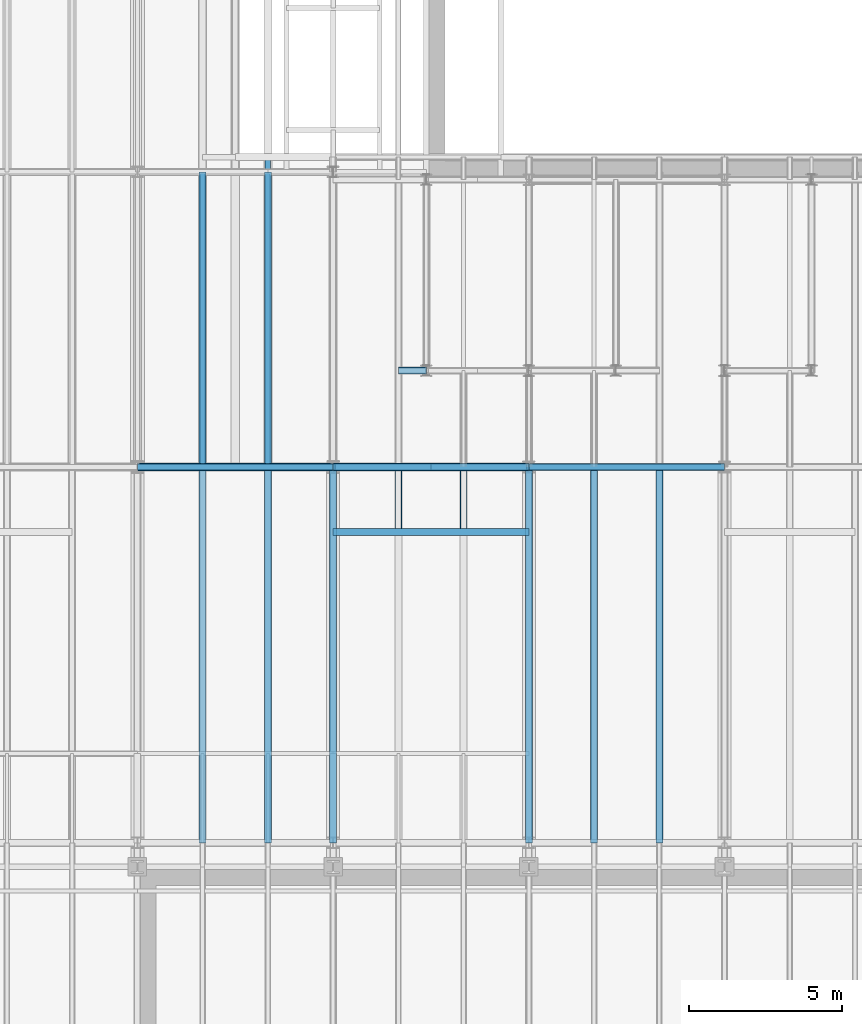
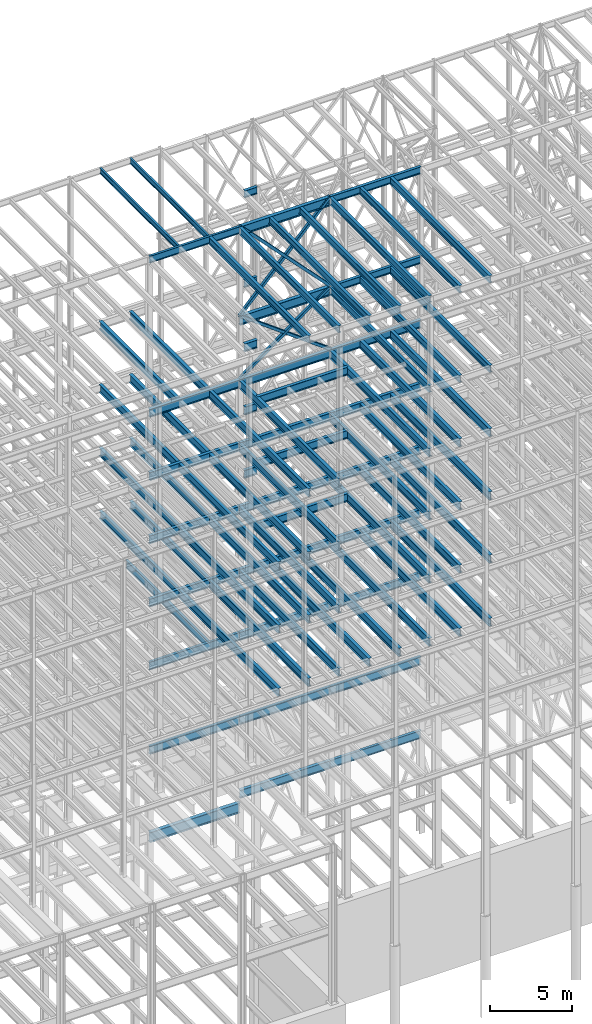
# One storey, part 132 of 150: 84 beams.
"""IFC2X3 building model written with IfcOpenShell, lengths in millimetres."""

from ifc_helpers import new_model, si_unit, frame, origin_with_axes, origin_2d_with_axis, place, context, subcontext, project, spatial, hollow_rectangle, i_section, extrude, material, type_object, element, save


model = new_model("IFC2X3")

# Units and contexts
model_context = context("Model", 3, precision=1e-05, world=origin_with_axes())
body_context = subcontext(model_context, "Body", "Model", "MODEL_VIEW")
ifc_project = project(units=[si_unit("LENGTHUNIT", "METRE", prefix="MILLI"), si_unit("AREAUNIT", "SQUARE_METRE"), si_unit("VOLUMEUNIT", "CUBIC_METRE"), si_unit("MASSUNIT", "GRAM", prefix="KILO"), si_unit("TIMEUNIT", "SECOND"), si_unit("PLANEANGLEUNIT", "RADIAN"), si_unit("SOLIDANGLEUNIT", "STERADIAN"), si_unit("THERMODYNAMICTEMPERATUREUNIT", "DEGREE_CELSIUS"), si_unit("LUMINOUSINTENSITYUNIT", "LUMEN")], contexts=[model_context])

# Site, building, storey
site_placement = place(None, origin_with_axes())
site = spatial("IfcSite", under=ifc_project, at=site_placement, CompositionType="ELEMENT")
building_placement = place(site_placement, origin_with_axes())
building = spatial("IfcBuilding", under=site, at=building_placement, Name="Undefined", CompositionType="ELEMENT")
storey_placement = place(building_placement, origin_with_axes())
storey = spatial("IfcBuildingStorey", under=building, at=storey_placement, Name="Undefined", CompositionType="ELEMENT", Elevation=0.0)

# Beams
ifc_material_1 = material()
beam_type_1 = type_object("IfcBeamType", Name="HSS8X8X3/8", PredefinedType="NOTDEFINED")
for number, where, z_axis, x_axis, name in (
    (1, (56591.2, 22479.0, 54483.0), (0.593852272176561, 0.0, 0.804574097787603), (-0.804574097787604, 0.0, 0.59385227217656), "BEAM"),
    (2, (50190.4, 22479.0, 54483.0), (-0.593852272176556, 0.0, 0.804574097787607), (0.804574097787604, 0.0, 0.59385227217656), "BEAM"),
):
    element("IfcBeam", number, at=place(storey_placement, frame(where, z_axis=z_axis, x_axis=x_axis)), inside=storey, type_object=beam_type_1, material=ifc_material_1, Name=name, ObjectType="HSS8X8X3/8", context=body_context, shape_type="SweptSolid", body=[
        extrude(hollow_rectangle(XDim=203.2, YDim=203.2, WallThickness=9.525, InnerFilletRadius=9.5249, OuterFilletRadius=19.0499, at=origin_2d_with_axis()), frame((7955.51355978985, 0.0, -1.81898940354586e-12), z_axis=(-1.0, 0.0, 0.0), x_axis=(0.0, -1.0, 0.0)), (0.0, 0.0, 1.0), 7955.51355978984),
    ])
beam_type_2 = type_object("IfcBeamType", Name="HSS8X8X1/4", PredefinedType="NOTDEFINED")
beam_1_placement = place(storey_placement, frame((56591.2, 22479.0, 59207.4), z_axis=(0.723355546413844, 0.0, 0.690475744304121), x_axis=(-0.690475744304122, 0.0, 0.723355546413843)))
element("IfcBeam", 3, at=beam_1_placement, inside=storey, type_object=beam_type_2, material=ifc_material_1, Name="BEAM", ObjectType="HSS8X8X1/4", context=body_context, shape_type="SweptSolid", body=[
    extrude(hollow_rectangle(XDim=203.2, YDim=203.2, WallThickness=6.35, InnerFilletRadius=6.3499, OuterFilletRadius=12.6999, at=origin_2d_with_axis()), frame((9270.13009617449, 3.63797880709171e-12, 0.0), z_axis=(-1.0, 0.0, 0.0), x_axis=(0.0, -1.0, 0.0)), (0.0, 0.0, 1.0), 9270.13009617449),
])
beam_2_placement = place(storey_placement, frame((50190.4, 22479.0, 59207.4), z_axis=(-0.723355546413844, 0.0, 0.690475744304121), x_axis=(0.690475744304122, 0.0, 0.723355546413843)))
element("IfcBeam", 4, at=beam_2_placement, inside=storey, type_object=beam_type_2, material=ifc_material_1, Name="BEAM", ObjectType="HSS8X8X1/4", context=body_context, shape_type="SweptSolid", body=[
    extrude(hollow_rectangle(XDim=203.2, YDim=203.2, WallThickness=6.35, InnerFilletRadius=6.3499, OuterFilletRadius=12.6999, at=origin_2d_with_axis()), frame((9270.13009617449, 3.63797880709171e-12, 0.0), z_axis=(-1.0, 0.0, 0.0), x_axis=(0.0, -1.0, 0.0)), (0.0, 0.0, 1.0), 9270.1300961745),
])
ifc_material_2 = material(Name="STEEL/A992")
beam_type_3 = type_object("IfcBeamType", Name="W16X31", PredefinedType="NOTDEFINED")
for number, where, z_axis, x_axis, name in (
    (5, (48056.8, 22479.0, 65711.3875), (0.0, 0.0, 1.0), (0.0, 1.0, 0.0), "BEAM"),
    (6, (45923.2, 22479.0, 65711.3875), (0.0, 0.0, 1.0), (0.0, 1.0, 0.0), "BEAM"),
):
    element("IfcBeam", number, at=place(storey_placement, frame(where, z_axis=z_axis, x_axis=x_axis)), inside=storey, type_object=beam_type_3, material=ifc_material_2, Name=name, ObjectType="W16X31", context=body_context, shape_type="SweptSolid", body=[
        extrude(i_section(OverallWidth=140.462, OverallDepth=403.225, WebThickness=6.3499, FlangeThickness=11.176, FilletRadius=17.399, at=origin_2d_with_axis()), frame((9652.0, 0.0, 0.0), z_axis=(-1.0, 0.0, 0.0), x_axis=(0.0, -1.0, 0.0)), (0.0, 0.0, 1.0), 9652.0),
    ])
beam_type_4 = type_object("IfcBeamType", Name="W21X50", PredefinedType="NOTDEFINED")
beam_3_placement = place(storey_placement, frame((43789.6, 22479.0, 65647.8875), z_axis=(0.0, 0.0, 1.0), x_axis=(1.0, 0.0, 0.0)))
element("IfcBeam", 7, at=beam_3_placement, inside=storey, type_object=beam_type_4, material=ifc_material_2, Name="BEAM", ObjectType="W21X50", context=body_context, shape_type="SweptSolid", body=[
    extrude(i_section(OverallWidth=165.862, OverallDepth=530.225, WebThickness=9.5249, FlangeThickness=13.589, FilletRadius=18.1609, at=origin_2d_with_axis()), frame((6400.80000000001, 0.0, 0.0), z_axis=(-1.0, 0.0, 0.0), x_axis=(0.0, -1.0, 0.0)), (0.0, 0.0, 1.0), 6400.80000000001),
])
beam_type_5 = type_object("IfcBeamType", Name="W24X68", PredefinedType="NOTDEFINED")
beam_4_placement = place(storey_placement, frame((50190.4, 20345.4, 54181.375), z_axis=(0.0, 0.0, 1.0), x_axis=(1.0, 0.0, 0.0)))
element("IfcBeam", 8, at=beam_4_placement, inside=storey, type_object=beam_type_5, material=ifc_material_2, Name="BEAM", ObjectType="W24X68", context=body_context, shape_type="SweptSolid", body=[
    extrude(i_section(OverallWidth=227.838, OverallDepth=603.25, WebThickness=11.1125, FlangeThickness=14.859, FilletRadius=23.2409, at=origin_2d_with_axis()), frame((6400.79935992001, 0.0, 0.0), z_axis=(-1.0, 0.0, 0.0), x_axis=(0.0, -1.0, 0.0)), (0.0, 0.0, 1.0), 6400.79935992),
])
beam_5_placement = place(storey_placement, frame((52324.0, 25628.6, 54181.375), z_axis=(0.0, 0.0, 1.0), x_axis=(1.0, 0.0, 0.0)))
element("IfcBeam", 9, at=beam_5_placement, inside=storey, type_object=beam_type_5, material=ifc_material_2, Name="BEAM", ObjectType="W24X68", context=body_context, shape_type="SweptSolid", body=[
    extrude(i_section(OverallWidth=227.838, OverallDepth=603.25, WebThickness=11.1125, FlangeThickness=14.859, FilletRadius=23.2409, at=origin_2d_with_axis()), frame((914.400000000009, 0.0, 0.0), z_axis=(-1.0, 0.0, 0.0), x_axis=(0.0, -1.0, 0.0)), (0.0, 0.0, 1.0), 914.400000000001),
])
for number, where, z_axis, x_axis, name in (
    (10, (48056.8, 22479.0, 54181.375), (0.0, 0.0, 1.0), (0.0, 1.0, 0.0), "BEAM"),
    (11, (45923.2, 22479.0, 54181.375), (0.0, 0.0, 1.0), (0.0, 1.0, 0.0), "BEAM"),
):
    element("IfcBeam", number, at=place(storey_placement, frame(where, z_axis=z_axis, x_axis=x_axis)), inside=storey, type_object=beam_type_5, material=ifc_material_2, Name=name, ObjectType="W24X68", context=body_context, shape_type="SweptSolid", body=[
        extrude(i_section(OverallWidth=227.838, OverallDepth=603.25, WebThickness=11.1125, FlangeThickness=14.859, FilletRadius=23.2409, at=origin_2d_with_axis()), frame((9652.0, 0.0, 0.0), z_axis=(-1.0, 0.0, 0.0), x_axis=(0.0, -1.0, 0.0)), (0.0, 0.0, 1.0), 9652.0),
    ])
beam_6_placement = place(storey_placement, frame((56591.2, 22479.0, 54181.375), z_axis=(0.0, 0.0, 1.0), x_axis=(1.0, 0.0, 0.0)))
element("IfcBeam", 12, at=beam_6_placement, inside=storey, type_object=beam_type_5, material=ifc_material_2, Name="BEAM", ObjectType="W24X68", context=body_context, shape_type="SweptSolid", body=[
    extrude(i_section(OverallWidth=227.838, OverallDepth=603.25, WebThickness=11.1125, FlangeThickness=14.859, FilletRadius=23.2409, at=origin_2d_with_axis()), frame((6400.79935992001, 0.0, 0.0), z_axis=(-1.0, 0.0, 0.0), x_axis=(0.0, -1.0, 0.0)), (0.0, 0.0, 1.0), 6400.79935992001),
])
beam_7_placement = place(storey_placement, frame((50190.4, 22479.0, 54181.375), z_axis=(0.0, 0.0, 1.0), x_axis=(1.0, 0.0, 0.0)))
element("IfcBeam", 13, at=beam_7_placement, inside=storey, type_object=beam_type_5, material=ifc_material_2, Name="BEAM", ObjectType="W24X68", context=body_context, shape_type="SweptSolid", body=[
    extrude(i_section(OverallWidth=227.838, OverallDepth=603.25, WebThickness=11.1125, FlangeThickness=14.859, FilletRadius=23.2409, at=origin_2d_with_axis()), frame((6400.80000000001, 0.0, 0.0), z_axis=(-1.0, 0.0, 0.0), x_axis=(0.0, -1.0, 0.0)), (0.0, 0.0, 1.0), 6400.8),
])
beam_8_placement = place(storey_placement, frame((43789.6, 22479.0, 54181.375), z_axis=(0.0, 0.0, 1.0), x_axis=(1.0, 0.0, 0.0)))
element("IfcBeam", 14, at=beam_8_placement, inside=storey, type_object=beam_type_5, material=ifc_material_2, Name="BEAM", ObjectType="W24X68", context=body_context, shape_type="SweptSolid", body=[
    extrude(i_section(OverallWidth=227.838, OverallDepth=603.25, WebThickness=11.1125, FlangeThickness=14.859, FilletRadius=23.2409, at=origin_2d_with_axis()), frame((6400.79935992001, 0.0, 0.0), z_axis=(-1.0, 0.0, 0.0), x_axis=(0.0, -1.0, 0.0)), (0.0, 0.0, 1.0), 6400.79935992001),
])
for number, where, z_axis, x_axis, name in (
    (15, (60858.4, 10185.4, 54181.375), (0.0, 0.0, 1.0), (0.0, 1.0, 0.0), "BEAM"),
    (16, (58724.8, 10185.4, 54181.375), (0.0, 0.0, 1.0), (0.0, 1.0, 0.0), "BEAM"),
    (17, (56591.2, 10185.4, 54181.375), (0.0, 0.0, 1.0), (0.0, 1.0, 0.0), "BEAM"),
    (18, (50190.4, 10185.4, 54181.375), (0.0, 0.0, 1.0), (0.0, 1.0, 0.0), "BEAM"),
    (19, (48056.8, 10185.4, 54181.375), (0.0, 0.0, 1.0), (0.0, 1.0, 0.0), "BEAM"),
):
    element("IfcBeam", number, at=place(storey_placement, frame(where, z_axis=z_axis, x_axis=x_axis)), inside=storey, type_object=beam_type_5, material=ifc_material_2, Name=name, ObjectType="W24X68", context=body_context, shape_type="SweptSolid", body=[
        extrude(i_section(OverallWidth=227.838, OverallDepth=603.25, WebThickness=11.1125, FlangeThickness=14.859, FilletRadius=23.2409, at=origin_2d_with_axis()), frame((12293.6, 0.0, 0.0), z_axis=(-1.0, 0.0, 0.0), x_axis=(0.0, -1.0, 0.0)), (0.0, 0.0, 1.0), 12293.6),
    ])
beam_9_placement = place(storey_placement, frame((50190.4, 20345.4, 49456.975), z_axis=(0.0, 0.0, 1.0), x_axis=(1.0, 0.0, 0.0)))
element("IfcBeam", 20, at=beam_9_placement, inside=storey, type_object=beam_type_5, material=ifc_material_2, Name="BEAM", ObjectType="W24X68", context=body_context, shape_type="SweptSolid", body=[
    extrude(i_section(OverallWidth=227.838, OverallDepth=603.25, WebThickness=11.1125, FlangeThickness=14.859, FilletRadius=23.2409, at=origin_2d_with_axis()), frame((6400.79935992001, 0.0, 0.0), z_axis=(-1.0, 0.0, 0.0), x_axis=(0.0, -1.0, 0.0)), (0.0, 0.0, 1.0), 6400.79935992),
])
beam_10_placement = place(storey_placement, frame((52324.0, 25628.6, 49456.975), z_axis=(0.0, 0.0, 1.0), x_axis=(1.0, 0.0, 0.0)))
element("IfcBeam", 21, at=beam_10_placement, inside=storey, type_object=beam_type_5, material=ifc_material_2, Name="BEAM", ObjectType="W24X68", context=body_context, shape_type="SweptSolid", body=[
    extrude(i_section(OverallWidth=227.838, OverallDepth=603.25, WebThickness=11.1125, FlangeThickness=14.859, FilletRadius=23.2409, at=origin_2d_with_axis()), frame((914.400000000009, 0.0, 0.0), z_axis=(-1.0, 0.0, 0.0), x_axis=(0.0, -1.0, 0.0)), (0.0, 0.0, 1.0), 914.400000000001),
])
for number, where, z_axis, x_axis, name in (
    (22, (48056.8, 22479.0, 49456.975), (0.0, 0.0, 1.0), (0.0, 1.0, 0.0), "BEAM"),
    (23, (45923.2, 22479.0, 49456.975), (0.0, 0.0, 1.0), (0.0, 1.0, 0.0), "BEAM"),
):
    element("IfcBeam", number, at=place(storey_placement, frame(where, z_axis=z_axis, x_axis=x_axis)), inside=storey, type_object=beam_type_5, material=ifc_material_2, Name=name, ObjectType="W24X68", context=body_context, shape_type="SweptSolid", body=[
        extrude(i_section(OverallWidth=227.838, OverallDepth=603.25, WebThickness=11.1125, FlangeThickness=14.859, FilletRadius=23.2409, at=origin_2d_with_axis()), frame((9652.0, 0.0, 0.0), z_axis=(-1.0, 0.0, 0.0), x_axis=(0.0, -1.0, 0.0)), (0.0, 0.0, 1.0), 9652.0),
    ])
beam_11_placement = place(storey_placement, frame((56591.2, 22479.0, 49456.975), z_axis=(0.0, 0.0, 1.0), x_axis=(1.0, 0.0, 0.0)))
element("IfcBeam", 24, at=beam_11_placement, inside=storey, type_object=beam_type_5, material=ifc_material_2, Name="BEAM", ObjectType="W24X68", context=body_context, shape_type="SweptSolid", body=[
    extrude(i_section(OverallWidth=227.838, OverallDepth=603.25, WebThickness=11.1125, FlangeThickness=14.859, FilletRadius=23.2409, at=origin_2d_with_axis()), frame((6400.79935992001, 0.0, 0.0), z_axis=(-1.0, 0.0, 0.0), x_axis=(0.0, -1.0, 0.0)), (0.0, 0.0, 1.0), 6400.79935992001),
])
beam_12_placement = place(storey_placement, frame((50190.4, 22479.0, 49456.975), z_axis=(0.0, 0.0, 1.0), x_axis=(1.0, 0.0, 0.0)))
element("IfcBeam", 25, at=beam_12_placement, inside=storey, type_object=beam_type_5, material=ifc_material_2, Name="BEAM", ObjectType="W24X68", context=body_context, shape_type="SweptSolid", body=[
    extrude(i_section(OverallWidth=227.838, OverallDepth=603.25, WebThickness=11.1125, FlangeThickness=14.859, FilletRadius=23.2409, at=origin_2d_with_axis()), frame((6400.79935992001, 0.0, 0.0), z_axis=(-1.0, 0.0, 0.0), x_axis=(0.0, -1.0, 0.0)), (0.0, 0.0, 1.0), 6400.79935992),
])
beam_13_placement = place(storey_placement, frame((43789.6, 22479.0, 49456.975), z_axis=(0.0, 0.0, 1.0), x_axis=(1.0, 0.0, 0.0)))
element("IfcBeam", 26, at=beam_13_placement, inside=storey, type_object=beam_type_5, material=ifc_material_2, Name="BEAM", ObjectType="W24X68", context=body_context, shape_type="SweptSolid", body=[
    extrude(i_section(OverallWidth=227.838, OverallDepth=603.25, WebThickness=11.1125, FlangeThickness=14.859, FilletRadius=23.2409, at=origin_2d_with_axis()), frame((6400.79935992001, 0.0, 0.0), z_axis=(-1.0, 0.0, 0.0), x_axis=(0.0, -1.0, 0.0)), (0.0, 0.0, 1.0), 6400.79935992001),
])
for number, where, z_axis, x_axis, name in (
    (27, (60858.4, 10185.4, 49456.975), (0.0, 0.0, 1.0), (0.0, 1.0, 0.0), "BEAM"),
    (28, (58724.8, 10185.4, 49456.975), (0.0, 0.0, 1.0), (0.0, 1.0, 0.0), "BEAM"),
    (29, (56591.2, 10185.4, 49456.975), (0.0, 0.0, 1.0), (0.0, 1.0, 0.0), "BEAM"),
    (30, (50190.4, 10185.4, 49456.975), (0.0, 0.0, 1.0), (0.0, 1.0, 0.0), "BEAM"),
    (31, (48056.8, 10185.4, 49456.975), (0.0, 0.0, 1.0), (0.0, 1.0, 0.0), "BEAM"),
    (32, (45923.2, 10185.4, 49456.975), (0.0, 0.0, 1.0), (0.0, 1.0, 0.0), "BEAM"),
):
    element("IfcBeam", number, at=place(storey_placement, frame(where, z_axis=z_axis, x_axis=x_axis)), inside=storey, type_object=beam_type_5, material=ifc_material_2, Name=name, ObjectType="W24X68", context=body_context, shape_type="SweptSolid", body=[
        extrude(i_section(OverallWidth=227.838, OverallDepth=603.25, WebThickness=11.1125, FlangeThickness=14.859, FilletRadius=23.2409, at=origin_2d_with_axis()), frame((12293.6, 0.0, 0.0), z_axis=(-1.0, 0.0, 0.0), x_axis=(0.0, -1.0, 0.0)), (0.0, 0.0, 1.0), 12293.6),
    ])
beam_14_placement = place(storey_placement, frame((50190.4, 20345.4, 44732.575), z_axis=(0.0, 0.0, 1.0), x_axis=(1.0, 0.0, 0.0)))
element("IfcBeam", 33, at=beam_14_placement, inside=storey, type_object=beam_type_5, material=ifc_material_2, Name="BEAM", ObjectType="W24X68", context=body_context, shape_type="SweptSolid", body=[
    extrude(i_section(OverallWidth=227.838, OverallDepth=603.25, WebThickness=11.1125, FlangeThickness=14.859, FilletRadius=23.2409, at=origin_2d_with_axis()), frame((6400.79935992001, 0.0, 0.0), z_axis=(-1.0, 0.0, 0.0), x_axis=(0.0, -1.0, 0.0)), (0.0, 0.0, 1.0), 6400.79935992),
])
beam_15_placement = place(storey_placement, frame((52324.0, 25628.6, 44732.575), z_axis=(0.0, 0.0, 1.0), x_axis=(1.0, 0.0, 0.0)))
element("IfcBeam", 34, at=beam_15_placement, inside=storey, type_object=beam_type_5, material=ifc_material_2, Name="BEAM", ObjectType="W24X68", context=body_context, shape_type="SweptSolid", body=[
    extrude(i_section(OverallWidth=227.838, OverallDepth=603.25, WebThickness=11.1125, FlangeThickness=14.859, FilletRadius=23.2409, at=origin_2d_with_axis()), frame((914.400000000009, 0.0, 0.0), z_axis=(-1.0, 0.0, 0.0), x_axis=(0.0, -1.0, 0.0)), (0.0, 0.0, 1.0), 914.400000000001),
])
for number, where, z_axis, x_axis, name in (
    (35, (48056.8, 22479.0, 44732.575), (0.0, 0.0, 1.0), (0.0, 1.0, 0.0), "BEAM"),
    (36, (45923.2, 22479.0, 44732.575), (0.0, 0.0, 1.0), (0.0, 1.0, 0.0), "BEAM"),
):
    element("IfcBeam", number, at=place(storey_placement, frame(where, z_axis=z_axis, x_axis=x_axis)), inside=storey, type_object=beam_type_5, material=ifc_material_2, Name=name, ObjectType="W24X68", context=body_context, shape_type="SweptSolid", body=[
        extrude(i_section(OverallWidth=227.838, OverallDepth=603.25, WebThickness=11.1125, FlangeThickness=14.859, FilletRadius=23.2409, at=origin_2d_with_axis()), frame((9652.0, 0.0, 0.0), z_axis=(-1.0, 0.0, 0.0), x_axis=(0.0, -1.0, 0.0)), (0.0, 0.0, 1.0), 9652.0),
    ])
beam_16_placement = place(storey_placement, frame((56591.2, 22479.0, 44732.575), z_axis=(0.0, 0.0, 1.0), x_axis=(1.0, 0.0, 0.0)))
element("IfcBeam", 37, at=beam_16_placement, inside=storey, type_object=beam_type_5, material=ifc_material_2, Name="BEAM", ObjectType="W24X68", context=body_context, shape_type="SweptSolid", body=[
    extrude(i_section(OverallWidth=227.838, OverallDepth=603.25, WebThickness=11.1125, FlangeThickness=14.859, FilletRadius=23.2409, at=origin_2d_with_axis()), frame((6400.79935992001, 0.0, 0.0), z_axis=(-1.0, 0.0, 0.0), x_axis=(0.0, -1.0, 0.0)), (0.0, 0.0, 1.0), 6400.79935992001),
])
beam_17_placement = place(storey_placement, frame((50190.4, 22479.0, 44732.575), z_axis=(0.0, 0.0, 1.0), x_axis=(1.0, 0.0, 0.0)))
element("IfcBeam", 38, at=beam_17_placement, inside=storey, type_object=beam_type_5, material=ifc_material_2, Name="BEAM", ObjectType="W24X68", context=body_context, shape_type="SweptSolid", body=[
    extrude(i_section(OverallWidth=227.838, OverallDepth=603.25, WebThickness=11.1125, FlangeThickness=14.859, FilletRadius=23.2409, at=origin_2d_with_axis()), frame((6400.79935992001, 0.0, 0.0), z_axis=(-1.0, 0.0, 0.0), x_axis=(0.0, -1.0, 0.0)), (0.0, 0.0, 1.0), 6400.79935992),
])
beam_18_placement = place(storey_placement, frame((43789.6, 22479.0, 44732.575), z_axis=(0.0, 0.0, 1.0), x_axis=(1.0, 0.0, 0.0)))
element("IfcBeam", 39, at=beam_18_placement, inside=storey, type_object=beam_type_5, material=ifc_material_2, Name="BEAM", ObjectType="W24X68", context=body_context, shape_type="SweptSolid", body=[
    extrude(i_section(OverallWidth=227.838, OverallDepth=603.25, WebThickness=11.1125, FlangeThickness=14.859, FilletRadius=23.2409, at=origin_2d_with_axis()), frame((6400.79935992001, 0.0, 0.0), z_axis=(-1.0, 0.0, 0.0), x_axis=(0.0, -1.0, 0.0)), (0.0, 0.0, 1.0), 6400.79935992001),
])
for number, where, z_axis, x_axis, name in (
    (40, (60858.4, 10185.4, 44732.575), (0.0, 0.0, 1.0), (0.0, 1.0, 0.0), "BEAM"),
    (41, (58724.8, 10185.4, 44732.575), (0.0, 0.0, 1.0), (0.0, 1.0, 0.0), "BEAM"),
    (42, (56591.2, 10185.4, 44732.575), (0.0, 0.0, 1.0), (0.0, 1.0, 0.0), "BEAM"),
    (43, (50190.4, 10185.4, 44732.575), (0.0, 0.0, 1.0), (0.0, 1.0, 0.0), "BEAM"),
    (44, (48056.8, 10185.4, 44732.575), (0.0, 0.0, 1.0), (0.0, 1.0, 0.0), "BEAM"),
    (45, (45923.2, 10185.4, 44732.575), (0.0, 0.0, 1.0), (0.0, 1.0, 0.0), "BEAM"),
):
    element("IfcBeam", number, at=place(storey_placement, frame(where, z_axis=z_axis, x_axis=x_axis)), inside=storey, type_object=beam_type_5, material=ifc_material_2, Name=name, ObjectType="W24X68", context=body_context, shape_type="SweptSolid", body=[
        extrude(i_section(OverallWidth=227.838, OverallDepth=603.25, WebThickness=11.1125, FlangeThickness=14.859, FilletRadius=23.2409, at=origin_2d_with_axis()), frame((12293.6, 0.0, 0.0), z_axis=(-1.0, 0.0, 0.0), x_axis=(0.0, -1.0, 0.0)), (0.0, 0.0, 1.0), 12293.6),
    ])
for number, where, z_axis, x_axis, name in (
    (46, (48056.8, 22479.0, 40008.175), (0.0, 0.0, 1.0), (0.0, 1.0, 0.0), "BEAM"),
    (47, (45923.2, 22479.0, 40008.175), (0.0, 0.0, 1.0), (0.0, 1.0, 0.0), "BEAM"),
):
    element("IfcBeam", number, at=place(storey_placement, frame(where, z_axis=z_axis, x_axis=x_axis)), inside=storey, type_object=beam_type_5, material=ifc_material_2, Name=name, ObjectType="W24X68", context=body_context, shape_type="SweptSolid", body=[
        extrude(i_section(OverallWidth=227.838, OverallDepth=603.25, WebThickness=11.1125, FlangeThickness=14.859, FilletRadius=23.2409, at=origin_2d_with_axis()), frame((9652.0, 0.0, 0.0), z_axis=(-1.0, 0.0, 0.0), x_axis=(0.0, -1.0, 0.0)), (0.0, 0.0, 1.0), 9652.0),
    ])
beam_19_placement = place(storey_placement, frame((56591.2, 22479.0, 40008.175), z_axis=(0.0, 0.0, 1.0), x_axis=(1.0, 0.0, 0.0)))
element("IfcBeam", 48, at=beam_19_placement, inside=storey, type_object=beam_type_5, material=ifc_material_2, Name="BEAM", ObjectType="W24X68", context=body_context, shape_type="SweptSolid", body=[
    extrude(i_section(OverallWidth=227.838, OverallDepth=603.25, WebThickness=11.1125, FlangeThickness=14.859, FilletRadius=23.2409, at=origin_2d_with_axis()), frame((6400.80000000001, 0.0, 0.0), z_axis=(-1.0, 0.0, 0.0), x_axis=(0.0, -1.0, 0.0)), (0.0, 0.0, 1.0), 6400.80000000001),
])
beam_20_placement = place(storey_placement, frame((50190.4, 22479.0, 40008.175), z_axis=(0.0, 0.0, 1.0), x_axis=(1.0, 0.0, 0.0)))
element("IfcBeam", 49, at=beam_20_placement, inside=storey, type_object=beam_type_5, material=ifc_material_2, Name="BEAM", ObjectType="W24X68", context=body_context, shape_type="SweptSolid", body=[
    extrude(i_section(OverallWidth=227.838, OverallDepth=603.25, WebThickness=11.1125, FlangeThickness=14.859, FilletRadius=23.2409, at=origin_2d_with_axis()), frame((6400.80000000001, 0.0, 0.0), z_axis=(-1.0, 0.0, 0.0), x_axis=(0.0, -1.0, 0.0)), (0.0, 0.0, 1.0), 6400.8),
])
beam_21_placement = place(storey_placement, frame((43789.6, 22479.0, 40008.175), z_axis=(0.0, 0.0, 1.0), x_axis=(1.0, 0.0, 0.0)))
element("IfcBeam", 50, at=beam_21_placement, inside=storey, type_object=beam_type_5, material=ifc_material_2, Name="BEAM", ObjectType="W24X68", context=body_context, shape_type="SweptSolid", body=[
    extrude(i_section(OverallWidth=227.838, OverallDepth=603.25, WebThickness=11.1125, FlangeThickness=14.859, FilletRadius=23.2409, at=origin_2d_with_axis()), frame((6400.80000000001, 0.0, 0.0), z_axis=(-1.0, 0.0, 0.0), x_axis=(0.0, -1.0, 0.0)), (0.0, 0.0, 1.0), 6400.80000000001),
])
for number, where, z_axis, x_axis, name in (
    (51, (60858.4, 10185.4, 40008.175), (0.0, 0.0, 1.0), (0.0, 1.0, 0.0), "BEAM"),
    (52, (58724.8, 10185.4, 40008.175), (0.0, 0.0, 1.0), (0.0, 1.0, 0.0), "BEAM"),
    (53, (56591.2, 10185.4, 40008.175), (0.0, 0.0, 1.0), (0.0, 1.0, 0.0), "BEAM"),
    (54, (54457.6, 10185.4, 40008.175), (0.0, 0.0, 1.0), (0.0, 1.0, 0.0), "BEAM"),
    (55, (52324.0, 10185.4, 40008.175), (0.0, 0.0, 1.0), (0.0, 1.0, 0.0), "BEAM"),
    (56, (50190.4, 10185.4, 40008.175), (0.0, 0.0, 1.0), (0.0, 1.0, 0.0), "BEAM"),
    (57, (48056.8, 10185.4, 40008.175), (0.0, 0.0, 1.0), (0.0, 1.0, 0.0), "BEAM"),
    (58, (45923.2, 10185.4, 40008.175), (0.0, 0.0, 1.0), (0.0, 1.0, 0.0), "BEAM"),
):
    element("IfcBeam", number, at=place(storey_placement, frame(where, z_axis=z_axis, x_axis=x_axis)), inside=storey, type_object=beam_type_5, material=ifc_material_2, Name=name, ObjectType="W24X68", context=body_context, shape_type="SweptSolid", body=[
        extrude(i_section(OverallWidth=227.838, OverallDepth=603.25, WebThickness=11.1125, FlangeThickness=14.859, FilletRadius=23.2409, at=origin_2d_with_axis()), frame((12293.6, 0.0, 0.0), z_axis=(-1.0, 0.0, 0.0), x_axis=(0.0, -1.0, 0.0)), (0.0, 0.0, 1.0), 12293.6),
    ])
beam_22_placement = place(storey_placement, frame((50190.4, 22479.0, 35283.775), z_axis=(0.0, 0.0, 1.0), x_axis=(1.0, 0.0, 0.0)))
element("IfcBeam", 59, at=beam_22_placement, inside=storey, type_object=beam_type_5, material=ifc_material_2, Name="BEAM", ObjectType="W24X68", context=body_context, shape_type="SweptSolid", body=[
    extrude(i_section(OverallWidth=227.838, OverallDepth=603.25, WebThickness=11.1125, FlangeThickness=14.859, FilletRadius=23.2409, at=origin_2d_with_axis()), frame((6400.80000000001, 0.0, 0.0), z_axis=(-1.0, 0.0, 0.0), x_axis=(0.0, -1.0, 0.0)), (0.0, 0.0, 1.0), 6400.8),
])
beam_23_placement = place(storey_placement, frame((56591.2, 22479.0, 28984.575), z_axis=(0.0, 0.0, 1.0), x_axis=(1.0, 0.0, 0.0)))
element("IfcBeam", 60, at=beam_23_placement, inside=storey, type_object=beam_type_5, material=ifc_material_2, Name="BEAM", ObjectType="W24X68", context=body_context, shape_type="SweptSolid", body=[
    extrude(i_section(OverallWidth=227.838, OverallDepth=603.25, WebThickness=11.1125, FlangeThickness=14.859, FilletRadius=23.2409, at=origin_2d_with_axis()), frame((6400.80000000001, 0.0, 0.0), z_axis=(-1.0, 0.0, 0.0), x_axis=(0.0, -1.0, 0.0)), (0.0, 0.0, 1.0), 6400.80000000001),
])
beam_24_placement = place(storey_placement, frame((50190.4, 22479.0, 28984.575), z_axis=(0.0, 0.0, 1.0), x_axis=(1.0, 0.0, 0.0)))
element("IfcBeam", 61, at=beam_24_placement, inside=storey, type_object=beam_type_5, material=ifc_material_2, Name="BEAM", ObjectType="W24X68", context=body_context, shape_type="SweptSolid", body=[
    extrude(i_section(OverallWidth=227.838, OverallDepth=603.25, WebThickness=11.1125, FlangeThickness=14.859, FilletRadius=23.2409, at=origin_2d_with_axis()), frame((6400.80000000001, 0.0, 0.0), z_axis=(-1.0, 0.0, 0.0), x_axis=(0.0, -1.0, 0.0)), (0.0, 0.0, 1.0), 6400.8),
])
beam_25_placement = place(storey_placement, frame((43789.6, 22479.0, 28984.575), z_axis=(0.0, 0.0, 1.0), x_axis=(1.0, 0.0, 0.0)))
element("IfcBeam", 62, at=beam_25_placement, inside=storey, type_object=beam_type_5, material=ifc_material_2, Name="BEAM", ObjectType="W24X68", context=body_context, shape_type="SweptSolid", body=[
    extrude(i_section(OverallWidth=227.838, OverallDepth=603.25, WebThickness=11.1125, FlangeThickness=14.859, FilletRadius=23.2409, at=origin_2d_with_axis()), frame((6400.80000000001, 0.0, 0.0), z_axis=(-1.0, 0.0, 0.0), x_axis=(0.0, -1.0, 0.0)), (0.0, 0.0, 1.0), 6400.80000000001),
])
beam_26_placement = place(storey_placement, frame((50190.4, 22479.0, 23472.775), z_axis=(0.0, 0.0, 1.0), x_axis=(1.0, 0.0, 0.0)))
element("IfcBeam", 63, at=beam_26_placement, inside=storey, type_object=beam_type_5, material=ifc_material_2, Name="BEAM", ObjectType="W24X68", context=body_context, shape_type="SweptSolid", body=[
    extrude(i_section(OverallWidth=227.838, OverallDepth=603.25, WebThickness=11.1125, FlangeThickness=14.859, FilletRadius=23.2409, at=origin_2d_with_axis()), frame((6400.80000000001, 0.0, 0.0), z_axis=(-1.0, 0.0, 0.0), x_axis=(0.0, -1.0, 0.0)), (0.0, 0.0, 1.0), 6400.8),
])
beam_type_6 = type_object("IfcBeamType", Name="W21X55", PredefinedType="NOTDEFINED")
for number, where, z_axis, x_axis, name in (
    (64, (48056.8, 10185.4, 65649.475), (0.0, 0.0, 1.0), (0.0, 1.0, 0.0), "BEAM"),
    (65, (54457.6, 10185.4, 65649.475), (0.0, 0.0, 1.0), (0.0, 1.0, 0.0), "BEAM"),
    (66, (52324.0, 10185.4, 65649.475), (0.0, 0.0, 1.0), (0.0, 1.0, 0.0), "BEAM"),
    (67, (50190.4, 10185.4, 65649.475), (0.0, 0.0, 1.0), (0.0, 1.0, 0.0), "BEAM"),
):
    element("IfcBeam", number, at=place(storey_placement, frame(where, z_axis=z_axis, x_axis=x_axis)), inside=storey, type_object=beam_type_6, material=ifc_material_2, Name=name, ObjectType="W21X55", context=body_context, shape_type="SweptSolid", body=[
        extrude(i_section(OverallWidth=208.788, OverallDepth=527.05, WebThickness=9.5, FlangeThickness=13.2588, FilletRadius=16.8624, at=origin_2d_with_axis()), frame((12293.6, 0.0, 0.0), z_axis=(-1.0, 0.0, 0.0), x_axis=(0.0, -1.0, 0.0)), (0.0, 0.0, 1.0), 12293.6),
    ])
beam_27_placement = place(storey_placement, frame((52324.0, 25628.6, 65649.475), z_axis=(0.0, 0.0, 1.0), x_axis=(1.0, 0.0, 0.0)))
element("IfcBeam", 68, at=beam_27_placement, inside=storey, type_object=beam_type_6, material=ifc_material_2, Name="BEAM", ObjectType="W21X55", context=body_context, shape_type="SweptSolid", body=[
    extrude(i_section(OverallWidth=208.788, OverallDepth=527.05, WebThickness=9.5, FlangeThickness=13.2588, FilletRadius=16.8624, at=origin_2d_with_axis()), frame((914.400000000009, 0.0, 0.0), z_axis=(-1.0, 0.0, 0.0), x_axis=(0.0, -1.0, 0.0)), (0.0, 0.0, 1.0), 914.400000000009),
])
beam_28_placement = place(storey_placement, frame((56591.2, 22479.0, 65649.475), z_axis=(0.0, 0.0, 1.0), x_axis=(1.0, 0.0, 0.0)))
element("IfcBeam", 69, at=beam_28_placement, inside=storey, type_object=beam_type_6, material=ifc_material_2, Name="BEAM", ObjectType="W21X55", context=body_context, shape_type="SweptSolid", body=[
    extrude(i_section(OverallWidth=208.788, OverallDepth=527.05, WebThickness=9.5, FlangeThickness=13.2588, FilletRadius=16.8624, at=origin_2d_with_axis()), frame((6400.80000000001, 0.0, 0.0), z_axis=(-1.0, 0.0, 0.0), x_axis=(0.0, -1.0, 0.0)), (0.0, 0.0, 1.0), 6400.8),
])
for number, where, z_axis, x_axis, name in (
    (70, (60858.4, 10185.4, 65649.475), (0.0, 0.0, 1.0), (0.0, 1.0, 0.0), "BEAM"),
    (71, (58724.8, 10185.4, 65649.475), (0.0, 0.0, 1.0), (0.0, 1.0, 0.0), "BEAM"),
    (72, (56591.2, 10185.4, 65649.475), (0.0, 0.0, 1.0), (0.0, 1.0, 0.0), "BEAM"),
):
    element("IfcBeam", number, at=place(storey_placement, frame(where, z_axis=z_axis, x_axis=x_axis)), inside=storey, type_object=beam_type_6, material=ifc_material_2, Name=name, ObjectType="W21X55", context=body_context, shape_type="SweptSolid", body=[
        extrude(i_section(OverallWidth=208.788, OverallDepth=527.05, WebThickness=9.5, FlangeThickness=13.2588, FilletRadius=16.8624, at=origin_2d_with_axis()), frame((12293.6, 0.0, 0.0), z_axis=(-1.0, 0.0, 0.0), x_axis=(0.0, -1.0, 0.0)), (0.0, 0.0, 1.0), 12293.6),
    ])
beam_29_placement = place(storey_placement, frame((52324.0, 25628.6, 58943.875), z_axis=(0.0, 0.0, 1.0), x_axis=(1.0, 0.0, 0.0)))
element("IfcBeam", 73, at=beam_29_placement, inside=storey, type_object=beam_type_6, material=ifc_material_2, Name="BEAM", ObjectType="W21X55", context=body_context, shape_type="SweptSolid", body=[
    extrude(i_section(OverallWidth=208.788, OverallDepth=527.05, WebThickness=9.5, FlangeThickness=13.2588, FilletRadius=16.8624, at=origin_2d_with_axis()), frame((914.400000000009, 0.0, 0.0), z_axis=(-1.0, 0.0, 0.0), x_axis=(0.0, -1.0, 0.0)), (0.0, 0.0, 1.0), 914.400000000009),
])
beam_30_placement = place(storey_placement, frame((56591.2, 22479.0, 58943.875), z_axis=(0.0, 0.0, 1.0), x_axis=(1.0, 0.0, 0.0)))
element("IfcBeam", 74, at=beam_30_placement, inside=storey, type_object=beam_type_6, material=ifc_material_2, Name="BEAM", ObjectType="W21X55", context=body_context, shape_type="SweptSolid", body=[
    extrude(i_section(OverallWidth=208.788, OverallDepth=527.05, WebThickness=9.5, FlangeThickness=13.2588, FilletRadius=16.8624, at=origin_2d_with_axis()), frame((6400.80000000001, 0.0, 0.0), z_axis=(-1.0, 0.0, 0.0), x_axis=(0.0, -1.0, 0.0)), (0.0, 0.0, 1.0), 6400.8),
])
for number, where, z_axis, x_axis, name in (
    (75, (60858.4, 10185.4, 58943.875), (0.0, 0.0, 1.0), (0.0, 1.0, 0.0), "BEAM"),
    (76, (58724.8, 10185.4, 58943.875), (0.0, 0.0, 1.0), (0.0, 1.0, 0.0), "BEAM"),
    (77, (56591.2, 10185.4, 58943.875), (0.0, 0.0, 1.0), (0.0, 1.0, 0.0), "BEAM"),
):
    element("IfcBeam", number, at=place(storey_placement, frame(where, z_axis=z_axis, x_axis=x_axis)), inside=storey, type_object=beam_type_6, material=ifc_material_2, Name=name, ObjectType="W21X55", context=body_context, shape_type="SweptSolid", body=[
        extrude(i_section(OverallWidth=208.788, OverallDepth=527.05, WebThickness=9.5, FlangeThickness=13.2588, FilletRadius=16.8624, at=origin_2d_with_axis()), frame((12293.6, 0.0, 0.0), z_axis=(-1.0, 0.0, 0.0), x_axis=(0.0, -1.0, 0.0)), (0.0, 0.0, 1.0), 12293.6),
    ])
beam_type_7 = type_object("IfcBeamType", Name="W27X84", PredefinedType="NOTDEFINED")
for number, where, z_axis, x_axis, name in (
    (78, (50190.4, 22479.0, 65573.275), (0.0, 0.0, 1.0), (1.0, 0.0, 0.0), "BEAM"),
    (79, (50190.4, 22479.0, 58867.675), (0.0, 0.0, 1.0), (1.0, 0.0, 0.0), "BEAM"),
):
    element("IfcBeam", number, at=place(storey_placement, frame(where, z_axis=z_axis, x_axis=x_axis)), inside=storey, type_object=beam_type_7, material=ifc_material_2, Name=name, ObjectType="W27X84", context=body_context, shape_type="SweptSolid", body=[
        extrude(i_section(OverallWidth=254.0, OverallDepth=679.45, WebThickness=11.1125, FlangeThickness=16.256, FilletRadius=23.4314, at=origin_2d_with_axis()), frame((6400.80000000001, 0.0, 0.0), z_axis=(-1.0, 0.0, 0.0), x_axis=(0.0, -1.0, 0.0)), (0.0, 0.0, 1.0), 6400.8),
    ])
beam_type_8 = type_object("IfcBeamType", Name="W24X62", PredefinedType="NOTDEFINED")
beam_31_placement = place(storey_placement, frame((48056.8, 22479.0, 35283.775), z_axis=(0.0, 0.0, 1.0), x_axis=(0.0, 1.0, 0.0)))
element("IfcBeam", 80, at=beam_31_placement, inside=storey, type_object=beam_type_8, material=ifc_material_2, Name="BEAM", ObjectType="W24X62", context=body_context, shape_type="SweptSolid", body=[
    extrude(i_section(OverallWidth=177.8, OverallDepth=603.25, WebThickness=11.1125, FlangeThickness=14.986, FilletRadius=23.114, at=origin_2d_with_axis()), frame((10134.6, 0.0, 0.0), z_axis=(-1.0, 0.0, 0.0), x_axis=(0.0, -1.0, 0.0)), (0.0, 0.0, 1.0), 10134.6),
])
beam_32_placement = place(storey_placement, frame((56591.2, 22479.0, 35283.775), z_axis=(0.0, 0.0, 1.0), x_axis=(1.0, 0.0, 0.0)))
element("IfcBeam", 81, at=beam_32_placement, inside=storey, type_object=beam_type_8, material=ifc_material_2, Name="BEAM", ObjectType="W24X62", context=body_context, shape_type="SweptSolid", body=[
    extrude(i_section(OverallWidth=177.8, OverallDepth=603.25, WebThickness=11.1125, FlangeThickness=14.986, FilletRadius=23.114, at=origin_2d_with_axis()), frame((6400.80000000001, 0.0, 0.0), z_axis=(-1.0, 0.0, 0.0), x_axis=(0.0, -1.0, 0.0)), (0.0, 0.0, 1.0), 6400.80000000001),
])
beam_33_placement = place(storey_placement, frame((43789.6, 22479.0, 35283.775), z_axis=(0.0, 0.0, 1.0), x_axis=(1.0, 0.0, 0.0)))
element("IfcBeam", 82, at=beam_33_placement, inside=storey, type_object=beam_type_8, material=ifc_material_2, Name="BEAM", ObjectType="W24X62", context=body_context, shape_type="SweptSolid", body=[
    extrude(i_section(OverallWidth=177.8, OverallDepth=603.25, WebThickness=11.1125, FlangeThickness=14.986, FilletRadius=23.114, at=origin_2d_with_axis()), frame((6400.80000000001, 0.0, 0.0), z_axis=(-1.0, 0.0, 0.0), x_axis=(0.0, -1.0, 0.0)), (0.0, 0.0, 1.0), 6400.8),
])
beam_34_placement = place(storey_placement, frame((56591.2, 22479.0, 23472.775), z_axis=(0.0, 0.0, 1.0), x_axis=(1.0, 0.0, 0.0)))
element("IfcBeam", 83, at=beam_34_placement, inside=storey, type_object=beam_type_8, material=ifc_material_2, Name="BEAM", ObjectType="W24X62", context=body_context, shape_type="SweptSolid", body=[
    extrude(i_section(OverallWidth=177.8, OverallDepth=603.25, WebThickness=11.1125, FlangeThickness=14.986, FilletRadius=23.114, at=origin_2d_with_axis()), frame((6400.79935992001, 0.0, 0.0), z_axis=(-1.0, 0.0, 0.0), x_axis=(0.0, -1.0, 0.0)), (0.0, 0.0, 1.0), 6400.79935992001),
])
beam_type_9 = type_object("IfcBeamType", Name="W30X90", PredefinedType="NOTDEFINED")
beam_35_placement = place(storey_placement, frame((43789.6, 22479.0, 22485.35), z_axis=(0.0, 0.0, 1.0), x_axis=(1.0, 0.0, 0.0)))
element("IfcBeam", 84, at=beam_35_placement, inside=storey, type_object=beam_type_9, material=ifc_material_2, Name="BEAM", ObjectType="W30X90", context=body_context, shape_type="SweptSolid", body=[
    extrude(i_section(OverallWidth=264.16, OverallDepth=749.3, WebThickness=12.6999, FlangeThickness=15.494, FilletRadius=22.606, at=origin_2d_with_axis()), frame((6400.80000000001, 0.0, 0.0), z_axis=(-1.0, 0.0, 0.0), x_axis=(0.0, -1.0, 0.0)), (0.0, 0.0, 1.0), 6400.8),
])

save(model, "model.ifc")
